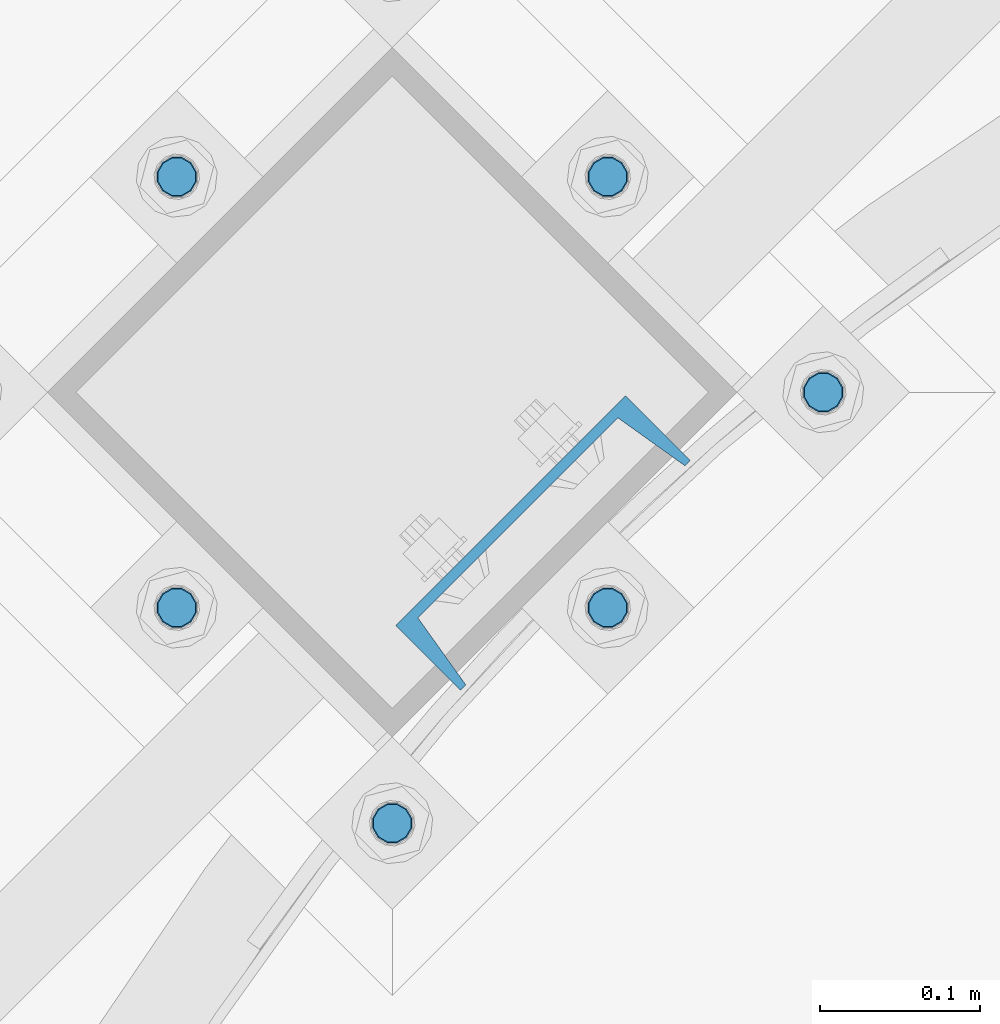
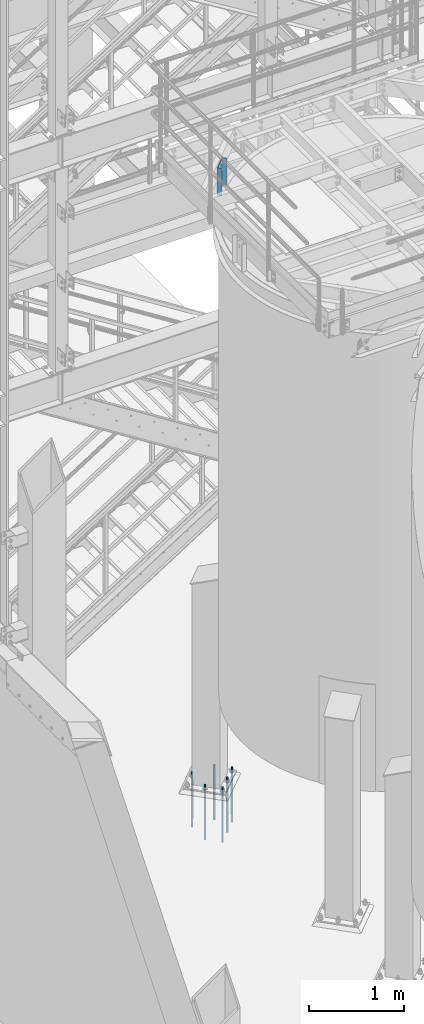
# One storey, part 806 of 1876: 7 columns, 2 elements without a shape of their own.
"""IFC2X3 building model written with IfcOpenShell, lengths in millimetres."""

from ifc_helpers import new_model, si_unit, frame, origin_with_axes, place, context, subcontext, project, spatial, faceted_brep, material, type_object, element, aggregate, save


model = new_model("IFC2X3")

# Units and contexts
model_context = context("Model", 3, precision=1e-05, world=origin_with_axes())
body_context = subcontext(model_context, "Body", "Model", "MODEL_VIEW")
ifc_project = project(units=[si_unit("LENGTHUNIT", "METRE", prefix="MILLI"), si_unit("AREAUNIT", "SQUARE_METRE"), si_unit("VOLUMEUNIT", "CUBIC_METRE"), si_unit("MASSUNIT", "GRAM", prefix="KILO"), si_unit("TIMEUNIT", "SECOND"), si_unit("PLANEANGLEUNIT", "RADIAN"), si_unit("SOLIDANGLEUNIT", "STERADIAN"), si_unit("THERMODYNAMICTEMPERATUREUNIT", "DEGREE_CELSIUS"), si_unit("LUMINOUSINTENSITYUNIT", "LUMEN")], contexts=[model_context])

# Site, building, storey
site_placement = place(None, origin_with_axes())
site = spatial("IfcSite", under=ifc_project, at=site_placement, CompositionType="ELEMENT")
building_placement = place(site_placement, origin_with_axes())
building = spatial("IfcBuilding", under=site, at=building_placement, Name="Undefined", CompositionType="ELEMENT")
storey_placement = place(building_placement, origin_with_axes())
storey = spatial("IfcBuildingStorey", under=building, at=storey_placement, Name="Undefined", CompositionType="ELEMENT", Elevation=0.0)

# Assembly, column
assembly_1_placement = place(storey_placement, origin_with_axes())
assembly_1 = element("IfcElementAssembly", 1, at=assembly_1_placement, inside=storey, Name="BEAM", AssemblyPlace="NOTDEFINED", PredefinedType="RIGID_FRAME")
ifc_material_1 = material(Name="STEEL/A36")
column_type_1 = type_object("IfcColumnType", Name="C8X11.5", PredefinedType="NOTDEFINED")
column_1_placement = place(assembly_1_placement, frame((3877.23860212195, -8233.17237314777, 7620.0), z_axis=(-0.707106781186547, -0.707106781186548, 0.0), x_axis=(0.0, 0.0, 1.0)))
column_1 = element("IfcColumn", 2, at=column_1_placement, type_object=column_type_1, material=ifc_material_1, Name="BEAM", ObjectType="C8X11.5", context=body_context, shape_type="Brep", body=[
    faceted_brep([(0.0, 28.5749999999998, -101.6), (0.0, 28.5749999999998, 101.6), (352.425, 28.5749999999998, 101.6), (352.425, 28.5749999999998, -101.6), (0.0, -28.5749999999998, 101.6), (352.425, -28.5749999999998, 101.6), (0.0, -28.5749999999998, 96.8355950000005), (352.425, -28.5749999999998, 96.8355950000005), (0.0, 22.2250000000004, 88.3723150000005), (352.425, 22.2250000000004, 88.3723150000005), (0.0, 22.2250000000004, -88.3723150000005), (352.425, 22.2250000000004, -88.3723150000005), (0.0, -28.5749999999998, -96.8355950000005), (352.425, -28.5749999999998, -96.8355950000005), (0.0, -28.5749999999998, -101.6), (352.425, -28.5749999999998, -101.6)], [[[0, 1, 2, 3]], [[1, 4, 5, 2]], [[4, 6, 7, 5]], [[6, 8, 9, 7]], [[8, 10, 11, 9]], [[10, 12, 13, 11]], [[12, 14, 15, 13]], [[14, 0, 3, 15]], [[5, 7, 9, 11, 13, 15, 3, 2]], [[14, 12, 10, 8, 6, 4, 1, 0]]]),
])
aggregate(assembly_1, [column_1])

# Assembly, columns
assembly_2_placement = place(storey_placement, origin_with_axes())
assembly_2 = element("IfcElementAssembly", 3, at=assembly_2_placement, inside=storey, Name="TEMPLATE", AssemblyPlace="NOTDEFINED", PredefinedType="RIGID_FRAME")
ifc_material_2 = material(Name="STEEL/F1554-GR.105")
column_type_2 = type_object("IfcColumnType", PredefinedType="NOTDEFINED")
column_2_placement = place(assembly_2_placement, frame((4052.42387743397, -8138.970378919, 7.105427357601e-15), z_axis=(0.707106781186548, 0.707106781186547, 0.0), x_axis=(0.0, 0.0, -1.0)))
column_2 = element("IfcColumn", 4, at=column_2_placement, type_object=column_type_2, material=ifc_material_2, Name="ANCHOR_BOLTS", context=body_context, shape_type="Brep", body=[
    faceted_brep([(-114.3, -10.3923048454853, 6.0000000001337), (-114.3, -6.00000000006912, 10.3923048455481), (-114.3, -6.54836185276508e-11, 12.0000000001355), (-114.3, 5.99999999993634, 10.3923048455481), (-114.3, 10.3923048453526, 6.00000000013279), (-114.3, 11.9999999999418, 1.29148247651756e-10), (-114.3, 10.3923048453507, -5.99999999987358), (-114.3, 5.99999999993815, -10.392304845288), (-114.3, -6.54836185276508e-11, -11.9999999998781), (-114.3, -6.00000000006912, -10.3923048452889), (-114.3, -10.3923048454853, -5.99999999987358), (-114.3, -12.0000000000728, 1.28238752949983e-10), (0.0, 11.9999999999418, 1.29148247651756e-10), (0.0, 10.3923048453507, -5.99999999987358), (0.0, 5.99999999993815, -10.392304845288), (0.0, -6.54836185276508e-11, -11.9999999998781), (0.0, -6.00000000006912, -10.3923048452889), (0.0, -10.3923048454853, -5.99999999987358), (0.0, -12.0000000000728, 1.28238752949983e-10), (0.0, -10.3923048454853, 6.0000000001337), (0.0, -6.00000000006912, 10.3923048455481), (0.0, -6.54836185276508e-11, 12.0000000001355), (0.0, 5.99999999993634, 10.3923048455481), (0.0, 10.3923048453526, 6.00000000013279), (0.0, -10.998522628066, 6.35000000000218), (0.0, -6.35000000000218, 10.9985226280642), (0.0, 0.0, 12.7000000000035), (0.0, 6.34999999999854, 10.9985226280651), (0.0, 10.9985226280623, 6.35000000000218), (0.0, 12.6999999999998, 0.0), (0.0, 10.9985226280623, -6.35000000000127), (0.0, 6.34999999999854, -10.9985226280633), (0.0, 0.0, -12.7000000000016), (0.0, -6.35000000000218, -10.9985226280642), (0.0, -10.998522628066, -6.35000000000127), (0.0, -12.6999999999998, 0.0), (488.95, -12.7000000000044, 9.09494701772928e-13), (488.95, -10.998522628066, 6.35000000000218), (488.95, -6.35000000000218, 10.9985226280642), (488.95, 0.0, 12.7000000000035), (488.95, 6.34999999999854, 10.9985226280651), (488.95, 10.9985226280623, 6.35000000000218), (488.95, 12.7000000000007, 9.09494701772928e-13), (488.95, 10.9985226280623, -6.35000000000127), (488.95, 6.34999999999854, -10.9985226280633), (488.95, 0.0, -12.7000000000016), (488.95, -6.35000000000218, -10.9985226280642), (488.95, -10.998522628066, -6.35000000000127), (488.95, -6.00000000006912, 10.3923048455481), (488.95, -6.54836185276508e-11, 12.0000000001355), (488.95, 5.99999999993634, 10.3923048455481), (488.95, 10.3923048453526, 6.00000000013279), (488.95, 11.9999999999418, 1.29148247651756e-10), (488.95, 10.3923048453507, -5.99999999987358), (488.95, 5.99999999993815, -10.392304845288), (488.95, -6.54836185276508e-11, -11.9999999998781), (488.95, -6.00000000006912, -10.3923048452889), (488.95, -10.3923048454853, -5.99999999987358), (488.95, -12.0000000000728, 1.28238752949983e-10), (488.95, -10.3923048454853, 6.0000000001337), (590.55, -6.00000000006912, -10.3923048452889), (590.55, -6.54836185276508e-11, -11.9999999998781), (590.55, 5.99999999993815, -10.392304845288), (590.55, 10.3923048453507, -5.99999999987358), (590.55, 11.9999999999418, 1.29148247651756e-10), (590.55, 10.3923048453526, 6.00000000013279), (590.55, 5.99999999993634, 10.3923048455481), (590.55, -6.54836185276508e-11, 12.0000000001355), (590.55, -6.00000000006912, 10.3923048455481), (590.55, -10.3923048454853, 6.0000000001337), (590.55, -12.0000000000728, 1.28238752949983e-10), (590.55, -10.3923048454853, -5.99999999987358)], [[[0, 1, 2, 3, 4, 5, 6, 7, 8, 9, 10, 11]], [[6, 5, 12, 13]], [[7, 6, 13, 14]], [[8, 7, 14, 15]], [[9, 8, 15, 16]], [[10, 9, 16, 17]], [[11, 10, 17, 18]], [[0, 11, 18, 19]], [[1, 0, 19, 20]], [[2, 1, 20, 21]], [[3, 2, 21, 22]], [[4, 3, 22, 23]], [[5, 4, 23, 12]], [[24, 25, 26, 27, 28, 29, 30, 31, 32, 33, 34, 35], [22, 21, 20, 19, 18, 17, 16, 15, 14, 13, 12, 23]], [[24, 35, 36, 37]], [[25, 24, 37, 38]], [[26, 25, 38, 39]], [[27, 26, 39, 40]], [[28, 27, 40, 41]], [[29, 28, 41, 42]], [[30, 29, 42, 43]], [[31, 30, 43, 44]], [[32, 31, 44, 45]], [[33, 32, 45, 46]], [[34, 33, 46, 47]], [[35, 34, 47, 36]], [[46, 45, 44, 43, 42, 41, 40, 39, 38, 37, 36, 47], [48, 49, 50, 51, 52, 53, 54, 55, 56, 57, 58, 59]], [[60, 61, 62, 63, 64, 65, 66, 67, 68, 69, 70, 71]], [[68, 67, 49, 48]], [[69, 68, 48, 59]], [[70, 69, 59, 58]], [[71, 70, 58, 57]], [[60, 71, 57, 56]], [[61, 60, 56, 55]], [[62, 61, 55, 54]], [[63, 62, 54, 53]], [[64, 63, 53, 52]], [[65, 64, 52, 51]], [[66, 65, 51, 50]], [[67, 66, 50, 49]]]),
])
column_3_placement = place(assembly_2_placement, frame((3917.72003561782, -8004.26653710285, 7.105427357601e-15), z_axis=(0.707106781186548, 0.707106781186547, 0.0), x_axis=(0.0, 0.0, -1.0)))
column_3 = element("IfcColumn", 5, at=column_3_placement, type_object=column_type_2, material=ifc_material_2, Name="ANCHOR_BOLTS", context=body_context, shape_type="Brep", body=[
    faceted_brep([(-114.3, -10.3923048454853, 6.0000000001337), (-114.3, -6.00000000006912, 10.3923048455481), (-114.3, -6.54836185276508e-11, 12.0000000001355), (-114.3, 5.99999999993634, 10.3923048455481), (-114.3, 10.3923048453526, 6.00000000013279), (-114.3, 11.9999999999418, 1.29148247651756e-10), (-114.3, 10.3923048453507, -5.99999999987358), (-114.3, 5.99999999993815, -10.392304845288), (-114.3, -6.54836185276508e-11, -11.9999999998781), (-114.3, -6.00000000006912, -10.3923048452889), (-114.3, -10.3923048454853, -5.99999999987358), (-114.3, -12.0000000000728, 1.28238752949983e-10), (0.0, 11.9999999999418, 1.29148247651756e-10), (0.0, 10.3923048453507, -5.99999999987358), (0.0, 5.99999999993815, -10.392304845288), (0.0, -6.54836185276508e-11, -11.9999999998781), (0.0, -6.00000000006912, -10.3923048452889), (0.0, -10.3923048454853, -5.99999999987358), (0.0, -12.0000000000728, 1.28238752949983e-10), (0.0, -10.3923048454853, 6.0000000001337), (0.0, -6.00000000006912, 10.3923048455481), (0.0, -6.54836185276508e-11, 12.0000000001355), (0.0, 5.99999999993634, 10.3923048455481), (0.0, 10.3923048453526, 6.00000000013279), (0.0, -10.998522628066, 6.35000000000218), (0.0, -6.35000000000218, 10.9985226280642), (0.0, 0.0, 12.7000000000035), (0.0, 6.34999999999854, 10.9985226280651), (0.0, 10.9985226280623, 6.35000000000218), (0.0, 12.6999999999998, 0.0), (0.0, 10.9985226280623, -6.35000000000127), (0.0, 6.34999999999854, -10.9985226280633), (0.0, 0.0, -12.7000000000016), (0.0, -6.35000000000218, -10.9985226280642), (0.0, -10.998522628066, -6.35000000000127), (0.0, -12.6999999999998, 0.0), (488.95, -12.7000000000044, 9.09494701772928e-13), (488.95, -10.998522628066, 6.35000000000218), (488.95, -6.35000000000218, 10.9985226280642), (488.95, 0.0, 12.7000000000035), (488.95, 6.34999999999854, 10.9985226280651), (488.95, 10.9985226280623, 6.35000000000218), (488.95, 12.7000000000007, 9.09494701772928e-13), (488.95, 10.9985226280623, -6.35000000000127), (488.95, 6.34999999999854, -10.9985226280633), (488.95, 0.0, -12.7000000000016), (488.95, -6.35000000000218, -10.9985226280642), (488.95, -10.998522628066, -6.35000000000127), (488.95, -6.00000000006912, 10.3923048455481), (488.95, -6.54836185276508e-11, 12.0000000001355), (488.95, 5.99999999993634, 10.3923048455481), (488.95, 10.3923048453526, 6.00000000013279), (488.95, 11.9999999999418, 1.29148247651756e-10), (488.95, 10.3923048453507, -5.99999999987358), (488.95, 5.99999999993815, -10.392304845288), (488.95, -6.54836185276508e-11, -11.9999999998781), (488.95, -6.00000000006912, -10.3923048452889), (488.95, -10.3923048454853, -5.99999999987358), (488.95, -12.0000000000728, 1.28238752949983e-10), (488.95, -10.3923048454853, 6.0000000001337), (590.55, -6.00000000006912, -10.3923048452889), (590.55, -6.54836185276508e-11, -11.9999999998781), (590.55, 5.99999999993815, -10.392304845288), (590.55, 10.3923048453507, -5.99999999987358), (590.55, 11.9999999999418, 1.29148247651756e-10), (590.55, 10.3923048453526, 6.00000000013279), (590.55, 5.99999999993634, 10.3923048455481), (590.55, -6.54836185276508e-11, 12.0000000001355), (590.55, -6.00000000006912, 10.3923048455481), (590.55, -10.3923048454853, 6.0000000001337), (590.55, -12.0000000000728, 1.28238752949983e-10), (590.55, -10.3923048454853, -5.99999999987358)], [[[0, 1, 2, 3, 4, 5, 6, 7, 8, 9, 10, 11]], [[6, 5, 12, 13]], [[7, 6, 13, 14]], [[8, 7, 14, 15]], [[9, 8, 15, 16]], [[10, 9, 16, 17]], [[11, 10, 17, 18]], [[0, 11, 18, 19]], [[1, 0, 19, 20]], [[2, 1, 20, 21]], [[3, 2, 21, 22]], [[4, 3, 22, 23]], [[5, 4, 23, 12]], [[24, 25, 26, 27, 28, 29, 30, 31, 32, 33, 34, 35], [22, 21, 20, 19, 18, 17, 16, 15, 14, 13, 12, 23]], [[24, 35, 36, 37]], [[25, 24, 37, 38]], [[26, 25, 38, 39]], [[27, 26, 39, 40]], [[28, 27, 40, 41]], [[29, 28, 41, 42]], [[30, 29, 42, 43]], [[31, 30, 43, 44]], [[32, 31, 44, 45]], [[33, 32, 45, 46]], [[34, 33, 46, 47]], [[35, 34, 47, 36]], [[46, 45, 44, 43, 42, 41, 40, 39, 38, 37, 36, 47], [48, 49, 50, 51, 52, 53, 54, 55, 56, 57, 58, 59]], [[60, 61, 62, 63, 64, 65, 66, 67, 68, 69, 70, 71]], [[68, 67, 49, 48]], [[69, 68, 48, 59]], [[70, 69, 59, 58]], [[71, 70, 58, 57]], [[60, 71, 57, 56]], [[61, 60, 56, 55]], [[62, 61, 55, 54]], [[63, 62, 54, 53]], [[64, 63, 53, 52]], [[65, 64, 52, 51]], [[66, 65, 51, 50]], [[67, 66, 50, 49]]]),
])
column_4_placement = place(assembly_2_placement, frame((3917.72003561782, -8273.67422073515, 7.105427357601e-15), z_axis=(0.707106781186548, 0.707106781186547, 0.0), x_axis=(0.0, 0.0, -1.0)))
column_4 = element("IfcColumn", 6, at=column_4_placement, type_object=column_type_2, material=ifc_material_2, Name="ANCHOR_BOLTS", context=body_context, shape_type="Brep", body=[
    faceted_brep([(-114.3, -10.3923048454853, 6.0000000001337), (-114.3, -6.00000000006912, 10.3923048455481), (-114.3, -6.54836185276508e-11, 12.0000000001355), (-114.3, 5.99999999993634, 10.3923048455481), (-114.3, 10.3923048453526, 6.00000000013279), (-114.3, 11.9999999999418, 1.29148247651756e-10), (-114.3, 10.3923048453507, -5.99999999987358), (-114.3, 5.99999999993815, -10.392304845288), (-114.3, -6.54836185276508e-11, -11.9999999998781), (-114.3, -6.00000000006912, -10.3923048452889), (-114.3, -10.3923048454853, -5.99999999987358), (-114.3, -12.0000000000728, 1.28238752949983e-10), (0.0, 11.9999999999418, 1.29148247651756e-10), (0.0, 10.3923048453507, -5.99999999987358), (0.0, 5.99999999993815, -10.392304845288), (0.0, -6.54836185276508e-11, -11.9999999998781), (0.0, -6.00000000006912, -10.3923048452889), (0.0, -10.3923048454853, -5.99999999987358), (0.0, -12.0000000000728, 1.28238752949983e-10), (0.0, -10.3923048454853, 6.0000000001337), (0.0, -6.00000000006912, 10.3923048455481), (0.0, -6.54836185276508e-11, 12.0000000001355), (0.0, 5.99999999993634, 10.3923048455481), (0.0, 10.3923048453526, 6.00000000013279), (0.0, -10.998522628066, 6.35000000000218), (0.0, -6.35000000000218, 10.9985226280642), (0.0, 0.0, 12.7000000000035), (0.0, 6.34999999999854, 10.9985226280651), (0.0, 10.9985226280623, 6.35000000000218), (0.0, 12.6999999999998, 0.0), (0.0, 10.9985226280623, -6.35000000000127), (0.0, 6.34999999999854, -10.9985226280633), (0.0, 0.0, -12.7000000000016), (0.0, -6.35000000000218, -10.9985226280642), (0.0, -10.998522628066, -6.35000000000127), (0.0, -12.6999999999998, 0.0), (488.95, -12.7000000000044, 9.09494701772928e-13), (488.95, -10.998522628066, 6.35000000000218), (488.95, -6.35000000000218, 10.9985226280642), (488.95, 0.0, 12.7000000000035), (488.95, 6.34999999999854, 10.9985226280651), (488.95, 10.9985226280623, 6.35000000000218), (488.95, 12.7000000000007, 9.09494701772928e-13), (488.95, 10.9985226280623, -6.35000000000127), (488.95, 6.34999999999854, -10.9985226280633), (488.95, 0.0, -12.7000000000016), (488.95, -6.35000000000218, -10.9985226280642), (488.95, -10.998522628066, -6.35000000000127), (488.95, -6.00000000006912, 10.3923048455481), (488.95, -6.54836185276508e-11, 12.0000000001355), (488.95, 5.99999999993634, 10.3923048455481), (488.95, 10.3923048453526, 6.00000000013279), (488.95, 11.9999999999418, 1.29148247651756e-10), (488.95, 10.3923048453507, -5.99999999987358), (488.95, 5.99999999993815, -10.392304845288), (488.95, -6.54836185276508e-11, -11.9999999998781), (488.95, -6.00000000006912, -10.3923048452889), (488.95, -10.3923048454853, -5.99999999987358), (488.95, -12.0000000000728, 1.28238752949983e-10), (488.95, -10.3923048454853, 6.0000000001337), (590.55, -6.00000000006912, -10.3923048452889), (590.55, -6.54836185276508e-11, -11.9999999998781), (590.55, 5.99999999993815, -10.392304845288), (590.55, 10.3923048453507, -5.99999999987358), (590.55, 11.9999999999418, 1.29148247651756e-10), (590.55, 10.3923048453526, 6.00000000013279), (590.55, 5.99999999993634, 10.3923048455481), (590.55, -6.54836185276508e-11, 12.0000000001355), (590.55, -6.00000000006912, 10.3923048455481), (590.55, -10.3923048454853, 6.0000000001337), (590.55, -12.0000000000728, 1.28238752949983e-10), (590.55, -10.3923048454853, -5.99999999987358)], [[[0, 1, 2, 3, 4, 5, 6, 7, 8, 9, 10, 11]], [[6, 5, 12, 13]], [[7, 6, 13, 14]], [[8, 7, 14, 15]], [[9, 8, 15, 16]], [[10, 9, 16, 17]], [[11, 10, 17, 18]], [[0, 11, 18, 19]], [[1, 0, 19, 20]], [[2, 1, 20, 21]], [[3, 2, 21, 22]], [[4, 3, 22, 23]], [[5, 4, 23, 12]], [[24, 25, 26, 27, 28, 29, 30, 31, 32, 33, 34, 35], [22, 21, 20, 19, 18, 17, 16, 15, 14, 13, 12, 23]], [[24, 35, 36, 37]], [[25, 24, 37, 38]], [[26, 25, 38, 39]], [[27, 26, 39, 40]], [[28, 27, 40, 41]], [[29, 28, 41, 42]], [[30, 29, 42, 43]], [[31, 30, 43, 44]], [[32, 31, 44, 45]], [[33, 32, 45, 46]], [[34, 33, 46, 47]], [[35, 34, 47, 36]], [[46, 45, 44, 43, 42, 41, 40, 39, 38, 37, 36, 47], [48, 49, 50, 51, 52, 53, 54, 55, 56, 57, 58, 59]], [[60, 61, 62, 63, 64, 65, 66, 67, 68, 69, 70, 71]], [[68, 67, 49, 48]], [[69, 68, 48, 59]], [[70, 69, 59, 58]], [[71, 70, 58, 57]], [[60, 71, 57, 56]], [[61, 60, 56, 55]], [[62, 61, 55, 54]], [[63, 62, 54, 53]], [[64, 63, 53, 52]], [[65, 64, 52, 51]], [[66, 65, 51, 50]], [[67, 66, 50, 49]]]),
])
column_5_placement = place(assembly_2_placement, frame((3648.31235198552, -8004.26653710284, 7.105427357601e-15), z_axis=(-0.707106781186547, -0.707106781186548, 0.0), x_axis=(0.0, 0.0, -1.0)))
column_5 = element("IfcColumn", 7, at=column_5_placement, type_object=column_type_2, material=ifc_material_2, Name="ANCHOR_BOLTS", context=body_context, shape_type="Brep", body=[
    faceted_brep([(-114.3, -10.3923048454853, 6.0000000001337), (-114.3, -6.00000000006912, 10.3923048455481), (-114.3, -6.54836185276508e-11, 12.0000000001355), (-114.3, 5.99999999993634, 10.3923048455481), (-114.3, 10.3923048453526, 6.00000000013279), (-114.3, 11.9999999999418, 1.29148247651756e-10), (-114.3, 10.3923048453507, -5.99999999987358), (-114.3, 5.99999999993815, -10.392304845288), (-114.3, -6.54836185276508e-11, -11.9999999998781), (-114.3, -6.00000000006912, -10.3923048452889), (-114.3, -10.3923048454853, -5.99999999987358), (-114.3, -12.0000000000728, 1.28238752949983e-10), (0.0, 11.9999999999418, 1.29148247651756e-10), (0.0, 10.3923048453507, -5.99999999987358), (0.0, 5.99999999993815, -10.392304845288), (0.0, -6.54836185276508e-11, -11.9999999998781), (0.0, -6.00000000006912, -10.3923048452889), (0.0, -10.3923048454853, -5.99999999987358), (0.0, -12.0000000000728, 1.28238752949983e-10), (0.0, -10.3923048454853, 6.0000000001337), (0.0, -6.00000000006912, 10.3923048455481), (0.0, -6.54836185276508e-11, 12.0000000001355), (0.0, 5.99999999993634, 10.3923048455481), (0.0, 10.3923048453526, 6.00000000013279), (0.0, -10.998522628066, 6.35000000000218), (0.0, -6.35000000000218, 10.9985226280642), (0.0, 0.0, 12.7000000000035), (0.0, 6.34999999999854, 10.9985226280651), (0.0, 10.9985226280623, 6.35000000000218), (0.0, 12.6999999999998, 0.0), (0.0, 10.9985226280623, -6.35000000000127), (0.0, 6.34999999999854, -10.9985226280633), (0.0, 0.0, -12.7000000000016), (0.0, -6.35000000000218, -10.9985226280642), (0.0, -10.998522628066, -6.35000000000127), (0.0, -12.6999999999998, 0.0), (488.95, -12.7000000000044, 9.09494701772928e-13), (488.95, -10.998522628066, 6.35000000000218), (488.95, -6.35000000000218, 10.9985226280642), (488.95, 0.0, 12.7000000000035), (488.95, 6.34999999999854, 10.9985226280651), (488.95, 10.9985226280623, 6.35000000000218), (488.95, 12.7000000000007, 9.09494701772928e-13), (488.95, 10.9985226280623, -6.35000000000127), (488.95, 6.34999999999854, -10.9985226280633), (488.95, 0.0, -12.7000000000016), (488.95, -6.35000000000218, -10.9985226280642), (488.95, -10.998522628066, -6.35000000000127), (488.95, -6.00000000006912, 10.3923048455481), (488.95, -6.54836185276508e-11, 12.0000000001355), (488.95, 5.99999999993634, 10.3923048455481), (488.95, 10.3923048453526, 6.00000000013279), (488.95, 11.9999999999418, 1.29148247651756e-10), (488.95, 10.3923048453507, -5.99999999987358), (488.95, 5.99999999993815, -10.392304845288), (488.95, -6.54836185276508e-11, -11.9999999998781), (488.95, -6.00000000006912, -10.3923048452889), (488.95, -10.3923048454853, -5.99999999987358), (488.95, -12.0000000000728, 1.28238752949983e-10), (488.95, -10.3923048454853, 6.0000000001337), (590.55, -6.00000000006912, -10.3923048452889), (590.55, -6.54836185276508e-11, -11.9999999998781), (590.55, 5.99999999993815, -10.392304845288), (590.55, 10.3923048453507, -5.99999999987358), (590.55, 11.9999999999418, 1.29148247651756e-10), (590.55, 10.3923048453526, 6.00000000013279), (590.55, 5.99999999993634, 10.3923048455481), (590.55, -6.54836185276508e-11, 12.0000000001355), (590.55, -6.00000000006912, 10.3923048455481), (590.55, -10.3923048454853, 6.0000000001337), (590.55, -12.0000000000728, 1.28238752949983e-10), (590.55, -10.3923048454853, -5.99999999987358)], [[[0, 1, 2, 3, 4, 5, 6, 7, 8, 9, 10, 11]], [[6, 5, 12, 13]], [[7, 6, 13, 14]], [[8, 7, 14, 15]], [[9, 8, 15, 16]], [[10, 9, 16, 17]], [[11, 10, 17, 18]], [[0, 11, 18, 19]], [[1, 0, 19, 20]], [[2, 1, 20, 21]], [[3, 2, 21, 22]], [[4, 3, 22, 23]], [[5, 4, 23, 12]], [[24, 25, 26, 27, 28, 29, 30, 31, 32, 33, 34, 35], [22, 21, 20, 19, 18, 17, 16, 15, 14, 13, 12, 23]], [[24, 35, 36, 37]], [[25, 24, 37, 38]], [[26, 25, 38, 39]], [[27, 26, 39, 40]], [[28, 27, 40, 41]], [[29, 28, 41, 42]], [[30, 29, 42, 43]], [[31, 30, 43, 44]], [[32, 31, 44, 45]], [[33, 32, 45, 46]], [[34, 33, 46, 47]], [[35, 34, 47, 36]], [[46, 45, 44, 43, 42, 41, 40, 39, 38, 37, 36, 47], [48, 49, 50, 51, 52, 53, 54, 55, 56, 57, 58, 59]], [[60, 61, 62, 63, 64, 65, 66, 67, 68, 69, 70, 71]], [[68, 67, 49, 48]], [[69, 68, 48, 59]], [[70, 69, 59, 58]], [[71, 70, 58, 57]], [[60, 71, 57, 56]], [[61, 60, 56, 55]], [[62, 61, 55, 54]], [[63, 62, 54, 53]], [[64, 63, 53, 52]], [[65, 64, 52, 51]], [[66, 65, 51, 50]], [[67, 66, 50, 49]]]),
])
column_6_placement = place(assembly_2_placement, frame((3783.01619380167, -8408.3780625513, 7.105427357601e-15), z_axis=(0.707106781186548, 0.707106781186547, 0.0), x_axis=(0.0, 0.0, -1.0)))
column_6 = element("IfcColumn", 8, at=column_6_placement, type_object=column_type_2, material=ifc_material_2, Name="ANCHOR_BOLTS", context=body_context, shape_type="Brep", body=[
    faceted_brep([(-114.3, -10.3923048454853, 6.0000000001337), (-114.3, -6.00000000006912, 10.3923048455481), (-114.3, -6.54836185276508e-11, 12.0000000001355), (-114.3, 5.99999999993634, 10.3923048455481), (-114.3, 10.3923048453526, 6.00000000013279), (-114.3, 11.9999999999418, 1.29148247651756e-10), (-114.3, 10.3923048453507, -5.99999999987358), (-114.3, 5.99999999993815, -10.392304845288), (-114.3, -6.54836185276508e-11, -11.9999999998781), (-114.3, -6.00000000006912, -10.3923048452889), (-114.3, -10.3923048454853, -5.99999999987358), (-114.3, -12.0000000000728, 1.28238752949983e-10), (0.0, 11.9999999999418, 1.29148247651756e-10), (0.0, 10.3923048453507, -5.99999999987358), (0.0, 5.99999999993815, -10.392304845288), (0.0, -6.54836185276508e-11, -11.9999999998781), (0.0, -6.00000000006912, -10.3923048452889), (0.0, -10.3923048454853, -5.99999999987358), (0.0, -12.0000000000728, 1.28238752949983e-10), (0.0, -10.3923048454853, 6.0000000001337), (0.0, -6.00000000006912, 10.3923048455481), (0.0, -6.54836185276508e-11, 12.0000000001355), (0.0, 5.99999999993634, 10.3923048455481), (0.0, 10.3923048453526, 6.00000000013279), (0.0, -10.998522628066, 6.35000000000218), (0.0, -6.35000000000218, 10.9985226280642), (0.0, 0.0, 12.7000000000035), (0.0, 6.34999999999854, 10.9985226280651), (0.0, 10.9985226280623, 6.35000000000218), (0.0, 12.6999999999998, 0.0), (0.0, 10.9985226280623, -6.35000000000127), (0.0, 6.34999999999854, -10.9985226280633), (0.0, 0.0, -12.7000000000016), (0.0, -6.35000000000218, -10.9985226280642), (0.0, -10.998522628066, -6.35000000000127), (0.0, -12.6999999999998, 0.0), (488.95, -12.7000000000044, 9.09494701772928e-13), (488.95, -10.998522628066, 6.35000000000218), (488.95, -6.35000000000218, 10.9985226280642), (488.95, 0.0, 12.7000000000035), (488.95, 6.34999999999854, 10.9985226280651), (488.95, 10.9985226280623, 6.35000000000218), (488.95, 12.7000000000007, 9.09494701772928e-13), (488.95, 10.9985226280623, -6.35000000000127), (488.95, 6.34999999999854, -10.9985226280633), (488.95, 0.0, -12.7000000000016), (488.95, -6.35000000000218, -10.9985226280642), (488.95, -10.998522628066, -6.35000000000127), (488.95, -6.00000000006912, 10.3923048455481), (488.95, -6.54836185276508e-11, 12.0000000001355), (488.95, 5.99999999993634, 10.3923048455481), (488.95, 10.3923048453526, 6.00000000013279), (488.95, 11.9999999999418, 1.29148247651756e-10), (488.95, 10.3923048453507, -5.99999999987358), (488.95, 5.99999999993815, -10.392304845288), (488.95, -6.54836185276508e-11, -11.9999999998781), (488.95, -6.00000000006912, -10.3923048452889), (488.95, -10.3923048454853, -5.99999999987358), (488.95, -12.0000000000728, 1.28238752949983e-10), (488.95, -10.3923048454853, 6.0000000001337), (590.55, -6.00000000006912, -10.3923048452889), (590.55, -6.54836185276508e-11, -11.9999999998781), (590.55, 5.99999999993815, -10.392304845288), (590.55, 10.3923048453507, -5.99999999987358), (590.55, 11.9999999999418, 1.29148247651756e-10), (590.55, 10.3923048453526, 6.00000000013279), (590.55, 5.99999999993634, 10.3923048455481), (590.55, -6.54836185276508e-11, 12.0000000001355), (590.55, -6.00000000006912, 10.3923048455481), (590.55, -10.3923048454853, 6.0000000001337), (590.55, -12.0000000000728, 1.28238752949983e-10), (590.55, -10.3923048454853, -5.99999999987358)], [[[0, 1, 2, 3, 4, 5, 6, 7, 8, 9, 10, 11]], [[6, 5, 12, 13]], [[7, 6, 13, 14]], [[8, 7, 14, 15]], [[9, 8, 15, 16]], [[10, 9, 16, 17]], [[11, 10, 17, 18]], [[0, 11, 18, 19]], [[1, 0, 19, 20]], [[2, 1, 20, 21]], [[3, 2, 21, 22]], [[4, 3, 22, 23]], [[5, 4, 23, 12]], [[24, 25, 26, 27, 28, 29, 30, 31, 32, 33, 34, 35], [22, 21, 20, 19, 18, 17, 16, 15, 14, 13, 12, 23]], [[24, 35, 36, 37]], [[25, 24, 37, 38]], [[26, 25, 38, 39]], [[27, 26, 39, 40]], [[28, 27, 40, 41]], [[29, 28, 41, 42]], [[30, 29, 42, 43]], [[31, 30, 43, 44]], [[32, 31, 44, 45]], [[33, 32, 45, 46]], [[34, 33, 46, 47]], [[35, 34, 47, 36]], [[46, 45, 44, 43, 42, 41, 40, 39, 38, 37, 36, 47], [48, 49, 50, 51, 52, 53, 54, 55, 56, 57, 58, 59]], [[60, 61, 62, 63, 64, 65, 66, 67, 68, 69, 70, 71]], [[68, 67, 49, 48]], [[69, 68, 48, 59]], [[70, 69, 59, 58]], [[71, 70, 58, 57]], [[60, 71, 57, 56]], [[61, 60, 56, 55]], [[62, 61, 55, 54]], [[63, 62, 54, 53]], [[64, 63, 53, 52]], [[65, 64, 52, 51]], [[66, 65, 51, 50]], [[67, 66, 50, 49]]]),
])
column_7_placement = place(assembly_2_placement, frame((3648.31235198551, -8273.67422073515, 7.105427357601e-15), z_axis=(0.707106781186548, 0.707106781186547, 0.0), x_axis=(0.0, 0.0, -1.0)))
column_7 = element("IfcColumn", 9, at=column_7_placement, type_object=column_type_2, material=ifc_material_2, Name="ANCHOR_BOLTS", context=body_context, shape_type="Brep", body=[
    faceted_brep([(-114.3, -10.3923048454853, 6.0000000001337), (-114.3, -6.00000000006912, 10.3923048455481), (-114.3, -6.54836185276508e-11, 12.0000000001355), (-114.3, 5.99999999993634, 10.3923048455481), (-114.3, 10.3923048453526, 6.00000000013279), (-114.3, 11.9999999999418, 1.29148247651756e-10), (-114.3, 10.3923048453507, -5.99999999987358), (-114.3, 5.99999999993815, -10.392304845288), (-114.3, -6.54836185276508e-11, -11.9999999998781), (-114.3, -6.00000000006912, -10.3923048452889), (-114.3, -10.3923048454853, -5.99999999987358), (-114.3, -12.0000000000728, 1.28238752949983e-10), (0.0, 11.9999999999418, 1.29148247651756e-10), (0.0, 10.3923048453507, -5.99999999987358), (0.0, 5.99999999993815, -10.392304845288), (0.0, -6.54836185276508e-11, -11.9999999998781), (0.0, -6.00000000006912, -10.3923048452889), (0.0, -10.3923048454853, -5.99999999987358), (0.0, -12.0000000000728, 1.28238752949983e-10), (0.0, -10.3923048454853, 6.0000000001337), (0.0, -6.00000000006912, 10.3923048455481), (0.0, -6.54836185276508e-11, 12.0000000001355), (0.0, 5.99999999993634, 10.3923048455481), (0.0, 10.3923048453526, 6.00000000013279), (0.0, -10.998522628066, 6.35000000000218), (0.0, -6.35000000000218, 10.9985226280642), (0.0, 0.0, 12.7000000000035), (0.0, 6.34999999999854, 10.9985226280651), (0.0, 10.9985226280623, 6.35000000000218), (0.0, 12.6999999999998, 0.0), (0.0, 10.9985226280623, -6.35000000000127), (0.0, 6.34999999999854, -10.9985226280633), (0.0, 0.0, -12.7000000000016), (0.0, -6.35000000000218, -10.9985226280642), (0.0, -10.998522628066, -6.35000000000127), (0.0, -12.6999999999998, 0.0), (488.95, -12.7000000000044, 9.09494701772928e-13), (488.95, -10.998522628066, 6.35000000000218), (488.95, -6.35000000000218, 10.9985226280642), (488.95, 0.0, 12.7000000000035), (488.95, 6.34999999999854, 10.9985226280651), (488.95, 10.9985226280623, 6.35000000000218), (488.95, 12.7000000000007, 9.09494701772928e-13), (488.95, 10.9985226280623, -6.35000000000127), (488.95, 6.34999999999854, -10.9985226280633), (488.95, 0.0, -12.7000000000016), (488.95, -6.35000000000218, -10.9985226280642), (488.95, -10.998522628066, -6.35000000000127), (488.95, -6.00000000006912, 10.3923048455481), (488.95, -6.54836185276508e-11, 12.0000000001355), (488.95, 5.99999999993634, 10.3923048455481), (488.95, 10.3923048453526, 6.00000000013279), (488.95, 11.9999999999418, 1.29148247651756e-10), (488.95, 10.3923048453507, -5.99999999987358), (488.95, 5.99999999993815, -10.392304845288), (488.95, -6.54836185276508e-11, -11.9999999998781), (488.95, -6.00000000006912, -10.3923048452889), (488.95, -10.3923048454853, -5.99999999987358), (488.95, -12.0000000000728, 1.28238752949983e-10), (488.95, -10.3923048454853, 6.0000000001337), (590.55, -6.00000000006912, -10.3923048452889), (590.55, -6.54836185276508e-11, -11.9999999998781), (590.55, 5.99999999993815, -10.392304845288), (590.55, 10.3923048453507, -5.99999999987358), (590.55, 11.9999999999418, 1.29148247651756e-10), (590.55, 10.3923048453526, 6.00000000013279), (590.55, 5.99999999993634, 10.3923048455481), (590.55, -6.54836185276508e-11, 12.0000000001355), (590.55, -6.00000000006912, 10.3923048455481), (590.55, -10.3923048454853, 6.0000000001337), (590.55, -12.0000000000728, 1.28238752949983e-10), (590.55, -10.3923048454853, -5.99999999987358)], [[[0, 1, 2, 3, 4, 5, 6, 7, 8, 9, 10, 11]], [[6, 5, 12, 13]], [[7, 6, 13, 14]], [[8, 7, 14, 15]], [[9, 8, 15, 16]], [[10, 9, 16, 17]], [[11, 10, 17, 18]], [[0, 11, 18, 19]], [[1, 0, 19, 20]], [[2, 1, 20, 21]], [[3, 2, 21, 22]], [[4, 3, 22, 23]], [[5, 4, 23, 12]], [[24, 25, 26, 27, 28, 29, 30, 31, 32, 33, 34, 35], [22, 21, 20, 19, 18, 17, 16, 15, 14, 13, 12, 23]], [[24, 35, 36, 37]], [[25, 24, 37, 38]], [[26, 25, 38, 39]], [[27, 26, 39, 40]], [[28, 27, 40, 41]], [[29, 28, 41, 42]], [[30, 29, 42, 43]], [[31, 30, 43, 44]], [[32, 31, 44, 45]], [[33, 32, 45, 46]], [[34, 33, 46, 47]], [[35, 34, 47, 36]], [[46, 45, 44, 43, 42, 41, 40, 39, 38, 37, 36, 47], [48, 49, 50, 51, 52, 53, 54, 55, 56, 57, 58, 59]], [[60, 61, 62, 63, 64, 65, 66, 67, 68, 69, 70, 71]], [[68, 67, 49, 48]], [[69, 68, 48, 59]], [[70, 69, 59, 58]], [[71, 70, 58, 57]], [[60, 71, 57, 56]], [[61, 60, 56, 55]], [[62, 61, 55, 54]], [[63, 62, 54, 53]], [[64, 63, 53, 52]], [[65, 64, 52, 51]], [[66, 65, 51, 50]], [[67, 66, 50, 49]]]),
])
aggregate(assembly_2, [column_2, column_3, column_4, column_5, column_6, column_7])

save(model, "model.ifc")
